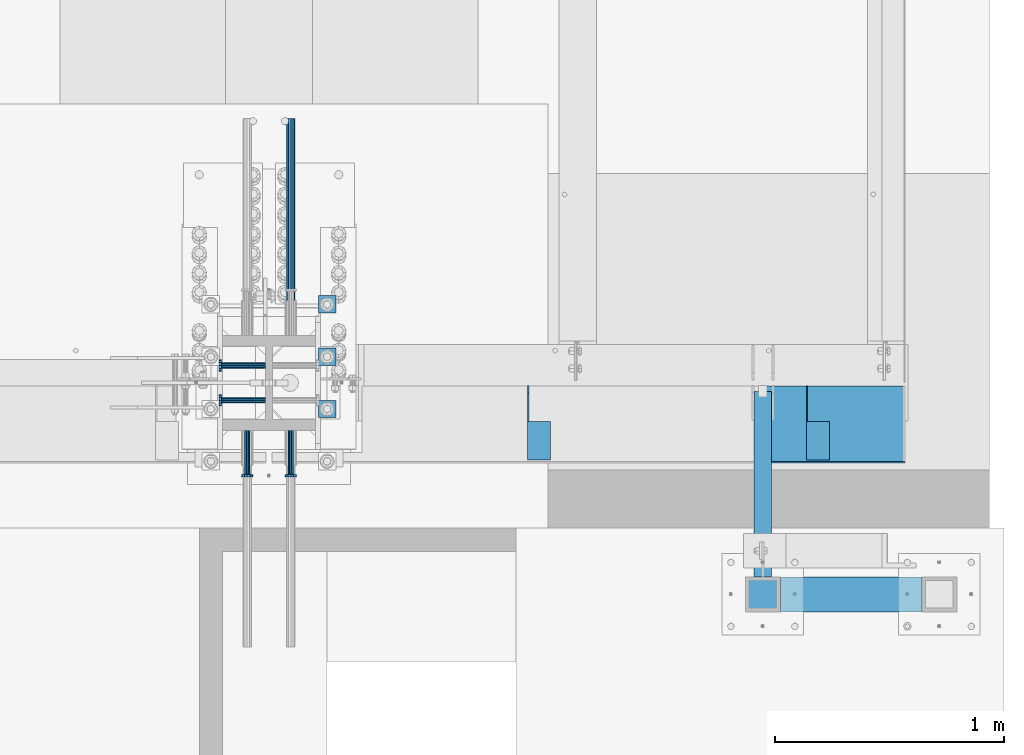
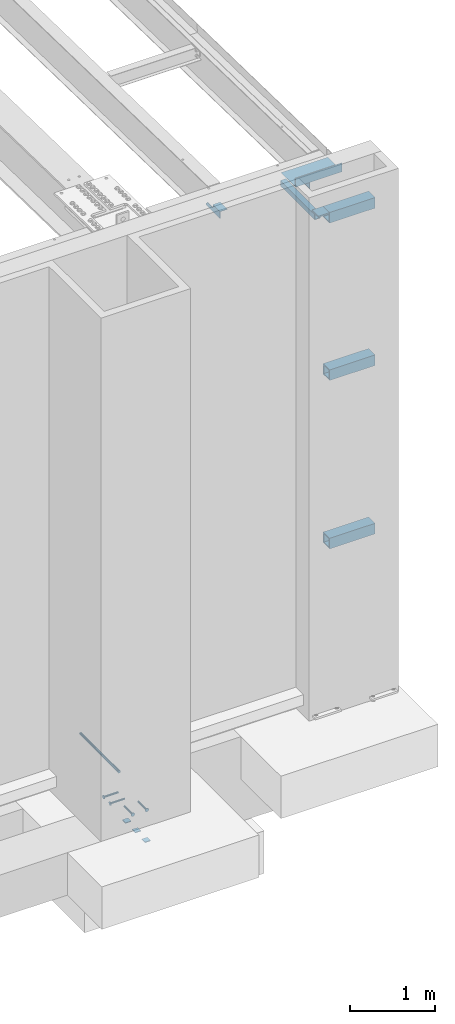
# One storey, part 1300 of 1763: 16 beams, 6 elements without a shape of their own.
"""IFC2X3 building model written with IfcOpenShell, lengths in millimetres."""

from ifc_helpers import new_model, si_unit, frame, origin_with_axes, place, context, subcontext, project, spatial, faceted_brep, material, type_object, element, aggregate, save


model = new_model("IFC2X3")

# Units and contexts
model_context = context("Model", 3, precision=1e-05, world=origin_with_axes())
body_context = subcontext(model_context, "Body", "Model", "MODEL_VIEW")
ifc_project = project(units=[si_unit("LENGTHUNIT", "METRE", prefix="MILLI"), si_unit("AREAUNIT", "SQUARE_METRE"), si_unit("VOLUMEUNIT", "CUBIC_METRE"), si_unit("MASSUNIT", "GRAM", prefix="KILO"), si_unit("TIMEUNIT", "SECOND"), si_unit("PLANEANGLEUNIT", "RADIAN"), si_unit("SOLIDANGLEUNIT", "STERADIAN"), si_unit("THERMODYNAMICTEMPERATUREUNIT", "DEGREE_CELSIUS"), si_unit("LUMINOUSINTENSITYUNIT", "LUMEN")], contexts=[model_context])

# Site, building, storey
site_placement = place(None, origin_with_axes())
site = spatial("IfcSite", under=ifc_project, at=site_placement, CompositionType="ELEMENT")
building_placement = place(site_placement, origin_with_axes())
building = spatial("IfcBuilding", under=site, at=building_placement, Name="Undefined", CompositionType="ELEMENT")
storey_placement = place(building_placement, origin_with_axes())
storey = spatial("IfcBuildingStorey", under=building, at=storey_placement, Name="Undefined", CompositionType="ELEMENT", Elevation=0.0)

# Assembly, beams
assembly_1_placement = place(storey_placement, origin_with_axes())
assembly_1 = element("IfcElementAssembly", 1, at=assembly_1_placement, inside=storey, Name="BEAM", AssemblyPlace="NOTDEFINED", PredefinedType="RIGID_FRAME")
ifc_material_1 = material(Name="STEEL/A36")
beam_type_1 = type_object("IfcBeamType", Name="L4X4X1/4", PredefinedType="NOTDEFINED")
beam_1_placement = place(assembly_1_placement, frame((-21628.4055562795, -13727.906068616, 12153.8999999997), z_axis=(0.0, 0.0, -1.0), x_axis=(0.0, -1.0, 0.0)))
beam_1 = element("IfcBeam", 2, at=beam_1_placement, type_object=beam_type_1, material=ifc_material_1, Name="BRACE", ObjectType="L4X4X1/4", context=body_context, shape_type="Brep", body=[
    faceted_brep([(31.7499984742426, 44.4500000000007, -6.35000000027321), (0.0, 44.4500000000007, 25.3999999997268), (0.0, 50.7999999999993, 25.3999999997268), (31.7499984742426, 50.7999999999993, -6.35000038323415), (-1.96450855582952e-10, 50.8000000000393, 50.7999999999374), (-1.81898940354586e-10, 44.4500000000371, 50.7999999999374), (324.643737794, 44.4500000000007, 50.7999999999993), (324.643737794, 50.7999999999993, 50.7999999999993), (324.643737794, -50.7999999999993, -50.7999999999993), (324.643737794, -50.7999999999993, -44.4500000000007), (156.368568202592, -50.7999999999993, -44.4500000000007), (156.368568386746, -50.7999999999993, -50.7999999999993), (324.643737794, 50.7999999999993, -50.7999999999993), (156.368568386746, 50.7999999999993, -50.7999999999993), (324.643737794, 44.4500000000007, -44.4500000000007), (156.368568202592, 44.4500000000007, -44.4500000000007), (156.368567097667, 44.4500000000007, -6.34999980941575), (156.368567097667, 50.7999999999993, -6.34999980941575)], [[[0, 1, 2, 3]], [[4, 5, 6, 7]], [[8, 9, 10, 11]], [[12, 8, 11, 13]], [[6, 14, 9, 8, 12, 7]], [[9, 14, 15, 10]], [[16, 17, 13, 11, 10, 15]], [[17, 16, 0, 3]], [[4, 7, 12, 13, 17, 3, 2]], [[5, 4, 2, 1]], [[16, 15, 14, 6, 5, 1, 0]]]),
])
beam_2_placement = place(assembly_1_placement, frame((-22847.6055562795, -13727.906068616, 12153.8999999997), z_axis=(0.0, 0.0, -1.0), x_axis=(0.0, -1.0, 0.0)))
beam_2 = element("IfcBeam", 3, at=beam_2_placement, type_object=beam_type_1, material=ifc_material_1, Name="BRACE", ObjectType="L4X4X1/4", context=body_context, shape_type="Brep", body=[
    faceted_brep([(31.7499984742426, 44.4500000000007, -6.35000000027321), (0.0, 44.4500000000007, 25.3999999997268), (0.0, 50.7999999999993, 25.3999999997268), (31.7499984742426, 50.7999999999993, -6.35000038323415), (-1.96450855582952e-10, 50.8000000000393, 50.7999999999374), (-1.81898940354586e-10, 44.4500000000371, 50.7999999999374), (324.643737794, 44.4500000000007, 50.7999999999993), (324.643737794, 50.7999999999993, 50.7999999999993), (324.643737794, -50.7999999999993, -50.7999999999993), (324.643737794, -50.7999999999993, -44.4500000000007), (156.368568202592, -50.7999999999993, -44.4500000000007), (156.368568386746, -50.7999999999993, -50.7999999999993), (324.643737794, 50.7999999999993, -50.7999999999993), (156.368568386746, 50.7999999999993, -50.7999999999993), (324.643737794, 44.4500000000007, -44.4500000000007), (156.368568202592, 44.4500000000007, -44.4500000000007), (156.368567097667, 44.4500000000007, -6.34999980941575), (156.368567097667, 50.7999999999993, -6.34999980941575)], [[[0, 1, 2, 3]], [[4, 5, 6, 7]], [[8, 9, 10, 11]], [[12, 8, 11, 13]], [[6, 14, 9, 8, 12, 7]], [[9, 14, 15, 10]], [[16, 17, 13, 11, 10, 15]], [[17, 16, 0, 3]], [[4, 7, 12, 13, 17, 3, 2]], [[5, 4, 2, 1]], [[16, 15, 14, 6, 5, 1, 0]]]),
])

# Assembly, beam
assembly_2_placement = place(storey_placement, origin_with_axes())
assembly_2 = element("IfcElementAssembly", 4, at=assembly_2_placement, inside=storey, Name="BEAM", AssemblyPlace="NOTDEFINED", PredefinedType="RIGID_FRAME")
ifc_material_2 = material()
beam_type_2 = type_object("IfcBeamType", Name="HSS3X3X1/4", PredefinedType="NOTDEFINED")
beam_3_placement = place(assembly_2_placement, frame((-21868.838056465, -14640.6431168969, 12084.05), z_axis=(0.0, 0.0, 1.0), x_axis=(0.0, 1.0, 0.0)))
beam_3 = element("IfcBeam", 5, at=beam_3_placement, type_object=beam_type_2, material=ifc_material_2, Name="BEAM", ObjectType="HSS3X3X1/4", context=body_context, shape_type="Brep", body=[
    faceted_brep([(76.1998186170622, 31.75, -31.75), (76.1998186170622, -31.75, -31.75), (887.337048279855, -31.75, -31.75), (887.337048279855, 31.75, -31.75), (76.1998186170622, -31.75, 31.75), (887.337048279855, -31.75, 31.75), (76.1998186170622, 31.75, 31.75), (887.337048279855, 31.75, 31.75), (76.1998186170622, 38.0999999999985, -38.1000000000004), (76.1998186170622, 38.0999999999985, 38.1000000000004), (887.337048279855, 38.0999999999985, 38.1000000000004), (887.337048279855, 38.0999999999985, -38.1000000000004), (76.1998186170622, -38.0999999999985, 38.1000000000004), (887.337048279855, -38.0999999999985, 38.1000000000004), (76.1998186170622, -38.0999999999985, -38.1000000000004), (887.337048279855, -38.0999999999985, -38.1000000000004)], [[[0, 1, 2, 3]], [[1, 4, 5, 2]], [[4, 6, 7, 5]], [[6, 0, 3, 7]], [[8, 9, 10, 11]], [[9, 12, 13, 10]], [[12, 14, 15, 13]], [[14, 8, 11, 15]], [[13, 15, 11, 10], [5, 7, 3, 2]], [[14, 12, 9, 8], [6, 4, 1, 0]]]),
])
aggregate(assembly_2, [beam_3])

# Assembly, beams
assembly_3_placement = place(storey_placement, origin_with_axes())
assembly_3 = element("IfcElementAssembly", 6, at=assembly_3_placement, inside=storey, Name="FRAME", AssemblyPlace="NOTDEFINED", PredefinedType="RIGID_FRAME")
beam_type_3 = type_object("IfcBeamType", PredefinedType="NOTDEFINED")
beam_4_placement = place(assembly_3_placement, frame((-21868.838056465, -14716.8432982799, 12195.175), z_axis=(1.0, 0.0, 0.0), x_axis=(0.0, 1.0, 0.0)))
beam_4 = element("IfcBeam", 7, at=beam_4_placement, type_object=beam_type_3, material=ifc_material_1, Name="PLATE", context=body_context, shape_type="Brep", body=[
    faceted_brep([(0.0, 9.52499999999964, -76.1999999999971), (0.0, 9.52499999999964, 76.1999999999971), (152.400000000001, 9.52499999999964, 76.1999999999971), (152.400000000001, 9.52499999999964, -76.1999999999971), (0.0, -9.52499999999964, 76.1999999999971), (152.400000000001, -9.52499999999964, 76.1999999999971), (0.0, -9.52499999999964, -76.1999999999971), (152.400000000001, -9.52499999999964, -76.1999999999971)], [[[0, 1, 2, 3]], [[1, 4, 5, 2]], [[4, 6, 7, 5]], [[6, 0, 3, 7]], [[5, 7, 3, 2]], [[6, 4, 1, 0]]]),
])
beam_type_4 = type_object("IfcBeamType", Name="HSS6X6X5/8", PredefinedType="NOTDEFINED")
beam_5_placement = place(assembly_3_placement, frame((-21868.8380579513, -14640.6432982799, 12128.5), z_axis=(0.0, 0.0, 1.0), x_axis=(1.0, 0.0, 0.0)))
beam_5 = element("IfcBeam", 8, at=beam_5_placement, type_object=beam_type_4, material=ifc_material_2, Name="BEAM", ObjectType="HSS6X6X5/8", context=body_context, shape_type="Brep", body=[
    faceted_brep([(76.2000014863552, 60.3250000000007, -60.3250000000007), (76.2000014863552, -60.3250000000007, -60.3250000000007), (695.325196798858, -60.3250000000007, -60.3250000000007), (695.325196798858, 60.3250000000007, -60.3250000000007), (76.2000027795075, -60.3250000000007, 60.3250000000007), (695.32519809201, -60.3250000000007, 60.3250000000007), (76.2000027795075, 60.3250000000007, 60.3250000000007), (695.32519809201, 60.3250000000007, 60.3250000000007), (76.2000014863552, 76.2000000000007, -76.2000000000007), (76.2000031128846, 76.2000000000007, 76.2000000000007), (695.325198425387, 76.2000000000007, 76.2000000000007), (695.325196798858, 76.2000000000007, -76.2000000000007), (76.2000031128846, -76.2000000000007, 76.2000000000007), (695.325198425387, -76.2000000000007, 76.2000000000007), (76.2000014863552, -76.2000000000007, -76.2000000000007), (695.325196798858, -76.2000000000007, -76.2000000000007)], [[[0, 1, 2, 3]], [[1, 4, 5, 2]], [[4, 6, 7, 5]], [[6, 0, 3, 7]], [[8, 9, 10, 11]], [[9, 12, 13, 10]], [[12, 14, 15, 13]], [[14, 8, 11, 15]], [[13, 15, 11, 10], [5, 7, 3, 2]], [[14, 12, 9, 8], [6, 4, 1, 0]]]),
])
beam_6_placement = place(assembly_3_placement, frame((-21868.8380574559, -14640.6432982799, 9867.9), z_axis=(0.0, 0.0, 1.0), x_axis=(1.0, 0.0, 0.0)))
beam_6 = element("IfcBeam", 9, at=beam_6_placement, type_object=beam_type_4, material=ifc_material_2, Name="BEAM", ObjectType="HSS6X6X5/8", context=body_context, shape_type="Brep", body=[
    faceted_brep([(76.2000014863552, 60.3250000000007, -60.3250000000007), (76.2000014863552, -60.3250000000007, -60.3250000000007), (695.325196798858, -60.3250000000007, -60.3250000000007), (695.325196798858, 60.3250000000007, -60.3250000000007), (76.2000027795075, -60.3250000000007, 60.3250000000007), (695.32519809201, -60.3250000000007, 60.3250000000007), (76.2000027795075, 60.3250000000007, 60.3250000000007), (695.32519809201, 60.3250000000007, 60.3250000000007), (76.2000014863552, 76.2000000000007, -76.2000000000007), (76.2000031128846, 76.2000000000007, 76.2000000000007), (695.325198425387, 76.2000000000007, 76.2000000000007), (695.325196798858, 76.2000000000007, -76.2000000000007), (76.2000031128846, -76.2000000000007, 76.2000000000007), (695.325198425387, -76.2000000000007, 76.2000000000007), (76.2000014863552, -76.2000000000007, -76.2000000000007), (695.325196798858, -76.2000000000007, -76.2000000000007)], [[[0, 1, 2, 3]], [[1, 4, 5, 2]], [[4, 6, 7, 5]], [[6, 0, 3, 7]], [[8, 9, 10, 11]], [[9, 12, 13, 10]], [[12, 14, 15, 13]], [[14, 8, 11, 15]], [[13, 15, 11, 10], [5, 7, 3, 2]], [[14, 12, 9, 8], [6, 4, 1, 0]]]),
])
beam_7_placement = place(assembly_3_placement, frame((-21868.8380569604, -14640.6432982799, 7448.55), z_axis=(0.0, 0.0, 1.0), x_axis=(1.0, 0.0, 0.0)))
beam_7 = element("IfcBeam", 10, at=beam_7_placement, type_object=beam_type_4, material=ifc_material_2, Name="BEAM", ObjectType="HSS6X6X5/8", context=body_context, shape_type="Brep", body=[
    faceted_brep([(76.2000014863552, 60.3250000000007, -60.3250000000007), (76.2000014863552, -60.3250000000007, -60.3250000000007), (695.325196798858, -60.3250000000007, -60.3250000000007), (695.325196798858, 60.3250000000007, -60.3250000000007), (76.2000027795075, -60.3250000000007, 60.3250000000007), (695.32519809201, -60.3250000000007, 60.3250000000007), (76.2000027795075, 60.3250000000007, 60.3250000000007), (695.32519809201, 60.3250000000007, 60.3250000000007), (76.2000014863552, 76.2000000000007, -76.2000000000007), (76.2000031128846, 76.2000000000007, 76.2000000000007), (695.325198425387, 76.2000000000007, 76.2000000000007), (695.325196798858, 76.2000000000007, -76.2000000000007), (76.2000031128846, -76.2000000000007, 76.2000000000007), (695.325198425387, -76.2000000000007, 76.2000000000007), (76.2000014863552, -76.2000000000007, -76.2000000000007), (695.325196798858, -76.2000000000007, -76.2000000000007)], [[[0, 1, 2, 3]], [[1, 4, 5, 2]], [[4, 6, 7, 5]], [[6, 0, 3, 7]], [[8, 9, 10, 11]], [[9, 12, 13, 10]], [[12, 14, 15, 13]], [[14, 8, 11, 15]], [[13, 15, 11, 10], [5, 7, 3, 2]], [[14, 12, 9, 8], [6, 4, 1, 0]]]),
])
aggregate(assembly_3, [beam_5, beam_6, beam_7, beam_4])

assembly_4_placement = place(storey_placement, origin_with_axes())
assembly_4 = element("IfcElementAssembly", 11, at=assembly_4_placement, inside=storey, Name="TEMPLATE", AssemblyPlace="NOTDEFINED", PredefinedType="RIGID_FRAME")
beam_type_5 = type_object("IfcBeamType", PredefinedType="NOTDEFINED")
beam_8_placement = place(assembly_4_placement, frame((-23773.8372736984, -13868.4000000001, 3348.0375), z_axis=(1.0, 0.0, 0.0), x_axis=(0.0, 1.0, 0.0)))
beam_8 = element("IfcBeam", 12, at=beam_8_placement, type_object=beam_type_5, material=ifc_material_1, Name="WASHER PLATE", context=body_context, shape_type="Brep", body=[
    faceted_brep([(0.0, 4.76249999999709, -38.1000000000004), (0.0, 4.76249999999709, 38.1000000000004), (76.2000000000007, 4.76249999999982, 38.0999999999985), (76.2000000000007, 4.76249999999982, -38.0999999999985), (0.0, -4.76249999999709, 38.1000000000004), (76.2000000000007, -4.76249999999982, 38.0999999999985), (0.0, -4.76249999999709, -38.1000000000004), (76.2000000000007, -4.76249999999982, -38.0999999999985)], [[[0, 1, 2, 3]], [[1, 4, 5, 2]], [[4, 6, 7, 5]], [[6, 0, 3, 7]], [[5, 7, 3, 2]], [[6, 4, 1, 0]]]),
])
beam_9_placement = place(assembly_4_placement, frame((-23773.8372736984, -13639.8000000001, 3348.0375), z_axis=(1.0, 0.0, 0.0), x_axis=(0.0, 1.0, 0.0)))
beam_9 = element("IfcBeam", 13, at=beam_9_placement, type_object=beam_type_5, material=ifc_material_1, Name="WASHER PLATE", context=body_context, shape_type="Brep", body=[
    faceted_brep([(0.0, 4.76249999999709, -38.1000000000004), (0.0, 4.76249999999709, 38.1000000000004), (76.2000000000007, 4.76249999999982, 38.0999999999985), (76.2000000000007, 4.76249999999982, -38.0999999999985), (0.0, -4.76249999999709, 38.1000000000004), (76.2000000000007, -4.76249999999982, 38.0999999999985), (0.0, -4.76249999999709, -38.1000000000004), (76.2000000000007, -4.76249999999982, -38.0999999999985)], [[[0, 1, 2, 3]], [[1, 4, 5, 2]], [[4, 6, 7, 5]], [[6, 0, 3, 7]], [[5, 7, 3, 2]], [[6, 4, 1, 0]]]),
])
beam_10_placement = place(assembly_4_placement, frame((-23773.8372736984, -13411.2000000001, 3348.0375), z_axis=(1.0, 0.0, 0.0), x_axis=(0.0, 1.0, 0.0)))
beam_10 = element("IfcBeam", 14, at=beam_10_placement, type_object=beam_type_5, material=ifc_material_1, Name="WASHER PLATE", context=body_context, shape_type="Brep", body=[
    faceted_brep([(0.0, 4.76249999999709, -38.1000000000004), (0.0, 4.76249999999709, 38.1000000000004), (76.2000000000007, 4.76249999999982, 38.0999999999985), (76.2000000000007, 4.76249999999982, -38.0999999999985), (0.0, -4.76249999999709, 38.1000000000004), (76.2000000000007, -4.76249999999982, 38.0999999999985), (0.0, -4.76249999999709, -38.1000000000004), (76.2000000000007, -4.76249999999982, -38.0999999999985)], [[[0, 1, 2, 3]], [[1, 4, 5, 2]], [[4, 6, 7, 5]], [[6, 0, 3, 7]], [[5, 7, 3, 2]], [[6, 4, 1, 0]]]),
])
aggregate(assembly_4, [beam_8, beam_9, beam_10])

# Assembly, beam
assembly_5_placement = place(storey_placement, origin_with_axes())
assembly_5 = element("IfcElementAssembly", 15, at=assembly_5_placement, inside=storey, Name="REBAR", AssemblyPlace="NOTDEFINED", PredefinedType="RIGID_FRAME")
ifc_material_3 = material(Name="STEEL/A706-GR.80")
beam_type_6 = type_object("IfcBeamType", Name="#11 REBAR", PredefinedType="NOTDEFINED")
beam_11_placement = place(assembly_5_placement, frame((-23932.5872736985, -13475.2717516257, 4165.60000000009), z_axis=(0.0, 0.0, 1.0), x_axis=(0.0, 1.0, 0.0)))
beam_11 = element("IfcBeam", 16, at=beam_11_placement, type_object=beam_type_6, material=ifc_material_3, Name="REBAR", ObjectType="#11 REBAR", context=body_context, shape_type="Brep", body=[
    faceted_brep([(0.0, -17.9069999999992, 0.0), (0.0, -15.507916905568, -8.95349999999962), (914.400000001086, -15.507916905568, -8.95349999999962), (914.400000001086, -17.9069999999992, 0.0), (0.0, -8.95349999999962, -15.507916905568), (914.400000001086, -8.95349999999962, -15.507916905568), (0.0, 0.0, -17.9070000000002), (914.400000001086, 0.0, -17.9070000000002), (0.0, 8.95349999999962, -15.507916905568), (914.400000001086, 8.95349999999962, -15.507916905568), (0.0, 15.507916905568, -8.95349999999962), (914.400000001086, 15.507916905568, -8.95349999999962), (0.0, 17.9069999999992, 0.0), (914.400000001086, 17.9069999999992, 0.0), (0.0, 15.507916905568, 8.95349999999962), (914.400000001086, 15.507916905568, 8.95349999999962), (0.0, 8.95349999999962, 15.507916905568), (914.400000001086, 8.95349999999962, 15.507916905568), (0.0, 0.0, 17.9070000000002), (914.400000001086, 0.0, 17.9070000000002), (0.0, -8.95349999999962, 15.507916905568), (914.400000001086, -8.95349999999962, 15.507916905568), (0.0, -15.507916905568, 8.95349999999962), (914.400000001086, -15.507916905568, 8.95349999999962)], [[[0, 1, 2, 3]], [[1, 4, 5, 2]], [[4, 6, 7, 5]], [[6, 8, 9, 7]], [[8, 10, 11, 9]], [[10, 12, 13, 11]], [[12, 14, 15, 13]], [[14, 16, 17, 15]], [[16, 18, 19, 17]], [[18, 20, 21, 19]], [[20, 22, 23, 21]], [[22, 0, 3, 23]], [[5, 7, 9, 11, 13, 15, 17, 19, 21, 23, 3, 2]], [[22, 20, 18, 16, 14, 12, 10, 8, 6, 4, 1, 0]]]),
])
aggregate(assembly_5, [beam_11])

# Assembly, beams
assembly_6_placement = place(storey_placement, origin_with_axes())
assembly_6 = element("IfcElementAssembly", 17, at=assembly_6_placement, inside=storey, Name="COLUMN", AssemblyPlace="NOTDEFINED", PredefinedType="RIGID_FRAME")
ifc_material_4 = material(Name="STEEL/A108")
beam_type_7 = type_object("IfcBeamType", PredefinedType="NOTDEFINED")
beam_12_placement = place(assembly_6_placement, frame((-24042.9185299162, -13639.800000342, 4013.2), z_axis=(0.0, -1.0, 0.0), x_axis=(-1.0, 0.0, 0.0)))
beam_12 = element("IfcBeam", 18, at=beam_12_placement, type_object=beam_type_7, material=ifc_material_4, Name="HEADED STUD ANCHOR", context=body_context, shape_type="Brep", body=[
    faceted_brep([(0.0, -12.6999999999971, -1.81898940354586e-12), (3.63797880709171e-12, -11.0, -6.34999990463257), (191.00799999576, -11.0, -6.34999990454889), (191.007999995752, -12.6999998092651, 8.36735125631094e-11), (7.27595761418343e-12, -6.34999990463257, -11.0), (191.00799999576, -6.34999990463257, -10.9999999999163), (3.63797880709171e-12, 0.0, -12.6999998092651), (191.00799999576, 0.0, -12.6999998091815), (7.27595761418343e-12, 6.34999990463257, -11.0), (191.00799999576, 6.34999990463257, -10.9999999999163), (3.63797880709171e-12, 11.0, -6.34999990463257), (191.00799999576, 11.0, -6.34999990454889), (0.0, 12.6999999999971, -1.81898940354586e-12), (191.007999995752, 12.6999998092651, 8.36735125631094e-11), (0.0, 11.0, 6.34999990463257), (191.007999995752, 11.0, 6.34999990471624), (-3.63797880709171e-12, 6.34999990463257, 11.0), (191.007999995749, 6.34999990463257, 11.0000000000837), (-3.63797880709171e-12, 0.0, 12.6999998092651), (191.007999995749, 0.0, 12.6999998093488), (-3.63797880709171e-12, -6.34999990463257, 11.0), (191.007999995749, -6.34999990463257, 11.0000000000837), (0.0, -11.0, 6.34999990463257), (191.007999995752, -11.0, 6.34999990471624), (193.039999995715, -22.0, -12.6999998091796), (193.039999995708, -25.3999996185303, 8.54925019666553e-11), (193.039999995719, -12.6999998092651, -21.9999999999145), (193.039999995719, 0.0, -25.3999996184448), (193.039999995719, 12.6999998092651, -21.9999999999145), (193.039999995715, 22.0, -12.6999998091796), (193.039999995708, 25.3999996185303, 8.54925019666553e-11), (193.039999995704, 22.0, 12.6999998093506), (193.039999995701, 12.6999998092651, 22.0000000000855), (193.039999995697, 0.0, 25.3999996186158), (193.039999995701, -12.6999998092651, 22.0000000000855), (193.039999995704, -22.0, 12.6999998093506), (203.199999995486, -22.0, -12.6999998091742), (203.199999995482, -25.3999996185303, 9.09494701772928e-11), (203.199999995493, -12.6999998092651, -21.9999999999091), (203.199999995493, 0.0, -25.3999996184393), (203.199999995493, 12.6999998092651, -21.9999999999091), (203.199999995486, 22.0, -12.6999998091742), (203.199999995482, 25.3999996185303, 9.09494701772928e-11), (203.199999995479, 22.0, 12.6999998093561), (203.199999995475, 12.6999998092651, 22.0000000000909), (203.199999995471, 0.0, 25.3999996186212), (203.199999995475, -12.6999998092651, 22.0000000000909), (203.199999995479, -22.0, 12.6999998093561)], [[[0, 1, 2, 3]], [[1, 4, 5, 2]], [[4, 6, 7, 5]], [[6, 8, 9, 7]], [[8, 10, 11, 9]], [[10, 12, 13, 11]], [[12, 14, 15, 13]], [[14, 16, 17, 15]], [[16, 18, 19, 17]], [[18, 20, 21, 19]], [[20, 22, 23, 21]], [[22, 0, 3, 23]], [[22, 20, 18, 16, 14, 12, 10, 8, 6, 4, 1, 0]], [[3, 2, 24, 25]], [[2, 5, 26, 24]], [[5, 7, 27, 26]], [[7, 9, 28, 27]], [[9, 11, 29, 28]], [[11, 13, 30, 29]], [[13, 15, 31, 30]], [[15, 17, 32, 31]], [[17, 19, 33, 32]], [[19, 21, 34, 33]], [[21, 23, 35, 34]], [[23, 3, 25, 35]], [[25, 24, 36, 37]], [[24, 26, 38, 36]], [[26, 27, 39, 38]], [[27, 28, 40, 39]], [[28, 29, 41, 40]], [[29, 30, 42, 41]], [[30, 31, 43, 42]], [[31, 32, 44, 43]], [[32, 33, 45, 44]], [[33, 34, 46, 45]], [[34, 35, 47, 46]], [[35, 25, 37, 47]], [[38, 39, 40, 41, 42, 43, 44, 45, 46, 47, 37, 36]]]),
])
beam_13_placement = place(assembly_6_placement, frame((-24042.9185298019, -13792.2000003411, 4013.2), z_axis=(0.0, -1.0, 0.0), x_axis=(-1.0, 0.0, 0.0)))
beam_13 = element("IfcBeam", 19, at=beam_13_placement, type_object=beam_type_7, material=ifc_material_4, Name="HEADED STUD ANCHOR", context=body_context, shape_type="Brep", body=[
    faceted_brep([(0.0, -12.6999999999971, -1.81898940354586e-12), (3.63797880709171e-12, -11.0, -6.34999990463257), (191.00799999576, -11.0, -6.34999990454889), (191.007999995752, -12.6999998092651, 8.36735125631094e-11), (7.27595761418343e-12, -6.34999990463257, -11.0), (191.00799999576, -6.34999990463257, -10.9999999999163), (3.63797880709171e-12, 0.0, -12.6999998092651), (191.00799999576, 0.0, -12.6999998091815), (7.27595761418343e-12, 6.34999990463257, -11.0), (191.00799999576, 6.34999990463257, -10.9999999999163), (3.63797880709171e-12, 11.0, -6.34999990463257), (191.00799999576, 11.0, -6.34999990454889), (0.0, 12.6999999999971, -1.81898940354586e-12), (191.007999995752, 12.6999998092651, 8.36735125631094e-11), (0.0, 11.0, 6.34999990463257), (191.007999995752, 11.0, 6.34999990471624), (-3.63797880709171e-12, 6.34999990463257, 11.0), (191.007999995749, 6.34999990463257, 11.0000000000837), (-3.63797880709171e-12, 0.0, 12.6999998092651), (191.007999995749, 0.0, 12.6999998093488), (-3.63797880709171e-12, -6.34999990463257, 11.0), (191.007999995749, -6.34999990463257, 11.0000000000837), (0.0, -11.0, 6.34999990463257), (191.007999995752, -11.0, 6.34999990471624), (193.039999995715, -22.0, -12.6999998091796), (193.039999995708, -25.3999996185303, 8.54925019666553e-11), (193.039999995719, -12.6999998092651, -21.9999999999145), (193.039999995719, 0.0, -25.3999996184448), (193.039999995719, 12.6999998092651, -21.9999999999145), (193.039999995715, 22.0, -12.6999998091796), (193.039999995708, 25.3999996185303, 8.54925019666553e-11), (193.039999995704, 22.0, 12.6999998093506), (193.039999995701, 12.6999998092651, 22.0000000000855), (193.039999995697, 0.0, 25.3999996186158), (193.039999995701, -12.6999998092651, 22.0000000000855), (193.039999995704, -22.0, 12.6999998093506), (203.199999995486, -22.0, -12.6999998091742), (203.199999995482, -25.3999996185303, 9.09494701772928e-11), (203.199999995493, -12.6999998092651, -21.9999999999091), (203.199999995493, 0.0, -25.3999996184393), (203.199999995493, 12.6999998092651, -21.9999999999091), (203.199999995486, 22.0, -12.6999998091742), (203.199999995482, 25.3999996185303, 9.09494701772928e-11), (203.199999995479, 22.0, 12.6999998093561), (203.199999995475, 12.6999998092651, 22.0000000000909), (203.199999995471, 0.0, 25.3999996186212), (203.199999995475, -12.6999998092651, 22.0000000000909), (203.199999995479, -22.0, 12.6999998093561)], [[[0, 1, 2, 3]], [[1, 4, 5, 2]], [[4, 6, 7, 5]], [[6, 8, 9, 7]], [[8, 10, 11, 9]], [[10, 12, 13, 11]], [[12, 14, 15, 13]], [[14, 16, 17, 15]], [[16, 18, 19, 17]], [[18, 20, 21, 19]], [[20, 22, 23, 21]], [[22, 0, 3, 23]], [[22, 20, 18, 16, 14, 12, 10, 8, 6, 4, 1, 0]], [[3, 2, 24, 25]], [[2, 5, 26, 24]], [[5, 7, 27, 26]], [[7, 9, 28, 27]], [[9, 11, 29, 28]], [[11, 13, 30, 29]], [[13, 15, 31, 30]], [[15, 17, 32, 31]], [[17, 19, 33, 32]], [[19, 21, 34, 33]], [[21, 23, 35, 34]], [[23, 3, 25, 35]], [[25, 24, 36, 37]], [[24, 26, 38, 36]], [[26, 27, 39, 38]], [[27, 28, 40, 39]], [[28, 29, 41, 40]], [[29, 30, 42, 41]], [[30, 31, 43, 42]], [[31, 32, 44, 43]], [[32, 33, 45, 44]], [[33, 34, 46, 45]], [[34, 35, 47, 46]], [[35, 25, 37, 47]], [[38, 39, 40, 41, 42, 43, 44, 45, 46, 47, 37, 36]]]),
])
beam_14_placement = place(assembly_6_placement, frame((-24123.0872736978, -13923.96256881, 4013.2), z_axis=(1.0, 0.0, 0.0), x_axis=(0.0, -1.0, 0.0)))
beam_14 = element("IfcBeam", 20, at=beam_14_placement, type_object=beam_type_7, material=ifc_material_4, Name="HEADED STUD ANCHOR", context=body_context, shape_type="Brep", body=[
    faceted_brep([(0.0, -12.6999999999971, -1.81898940354586e-12), (3.63797880709171e-12, -11.0, -6.34999990463257), (191.00799999576, -11.0, -6.34999990454889), (191.007999995752, -12.6999998092651, 8.36735125631094e-11), (7.27595761418343e-12, -6.34999990463257, -11.0), (191.00799999576, -6.34999990463257, -10.9999999999163), (3.63797880709171e-12, 0.0, -12.6999998092651), (191.00799999576, 0.0, -12.6999998091815), (7.27595761418343e-12, 6.34999990463257, -11.0), (191.00799999576, 6.34999990463257, -10.9999999999163), (3.63797880709171e-12, 11.0, -6.34999990463257), (191.00799999576, 11.0, -6.34999990454889), (0.0, 12.6999999999971, -1.81898940354586e-12), (191.007999995752, 12.6999998092651, 8.36735125631094e-11), (0.0, 11.0, 6.34999990463257), (191.007999995752, 11.0, 6.34999990471624), (-3.63797880709171e-12, 6.34999990463257, 11.0), (191.007999995749, 6.34999990463257, 11.0000000000837), (-3.63797880709171e-12, 0.0, 12.6999998092651), (191.007999995749, 0.0, 12.6999998093488), (-3.63797880709171e-12, -6.34999990463257, 11.0), (191.007999995749, -6.34999990463257, 11.0000000000837), (0.0, -11.0, 6.34999990463257), (191.007999995752, -11.0, 6.34999990471624), (193.039999995715, -22.0, -12.6999998091796), (193.039999995708, -25.3999996185303, 8.54925019666553e-11), (193.039999995719, -12.6999998092651, -21.9999999999145), (193.039999995719, 0.0, -25.3999996184448), (193.039999995719, 12.6999998092651, -21.9999999999145), (193.039999995715, 22.0, -12.6999998091796), (193.039999995708, 25.3999996185303, 8.54925019666553e-11), (193.039999995704, 22.0, 12.6999998093506), (193.039999995701, 12.6999998092651, 22.0000000000855), (193.039999995697, 0.0, 25.3999996186158), (193.039999995701, -12.6999998092651, 22.0000000000855), (193.039999995704, -22.0, 12.6999998093506), (203.199999995486, -22.0, -12.6999998091742), (203.199999995482, -25.3999996185303, 9.09494701772928e-11), (203.199999995493, -12.6999998092651, -21.9999999999091), (203.199999995493, 0.0, -25.3999996184393), (203.199999995493, 12.6999998092651, -21.9999999999091), (203.199999995486, 22.0, -12.6999998091742), (203.199999995482, 25.3999996185303, 9.09494701772928e-11), (203.199999995479, 22.0, 12.6999998093561), (203.199999995475, 12.6999998092651, 22.0000000000909), (203.199999995471, 0.0, 25.3999996186212), (203.199999995475, -12.6999998092651, 22.0000000000909), (203.199999995479, -22.0, 12.6999998093561)], [[[0, 1, 2, 3]], [[1, 4, 5, 2]], [[4, 6, 7, 5]], [[6, 8, 9, 7]], [[8, 10, 11, 9]], [[10, 12, 13, 11]], [[12, 14, 15, 13]], [[14, 16, 17, 15]], [[16, 18, 19, 17]], [[18, 20, 21, 19]], [[20, 22, 23, 21]], [[22, 0, 3, 23]], [[22, 20, 18, 16, 14, 12, 10, 8, 6, 4, 1, 0]], [[3, 2, 24, 25]], [[2, 5, 26, 24]], [[5, 7, 27, 26]], [[7, 9, 28, 27]], [[9, 11, 29, 28]], [[11, 13, 30, 29]], [[13, 15, 31, 30]], [[15, 17, 32, 31]], [[17, 19, 33, 32]], [[19, 21, 34, 33]], [[21, 23, 35, 34]], [[23, 3, 25, 35]], [[25, 24, 36, 37]], [[24, 26, 38, 36]], [[26, 27, 39, 38]], [[27, 28, 40, 39]], [[28, 29, 41, 40]], [[29, 30, 42, 41]], [[30, 31, 43, 42]], [[31, 32, 44, 43]], [[32, 33, 45, 44]], [[33, 34, 46, 45]], [[34, 35, 47, 46]], [[35, 25, 37, 47]], [[38, 39, 40, 41, 42, 43, 44, 45, 46, 47, 37, 36]]]),
])
beam_15_placement = place(assembly_6_placement, frame((-23932.5872736984, -13923.9626374705, 4013.2), z_axis=(1.0, 0.0, 0.0), x_axis=(0.0, -1.0, 0.0)))
beam_15 = element("IfcBeam", 21, at=beam_15_placement, type_object=beam_type_7, material=ifc_material_4, Name="HEADED STUD ANCHOR", context=body_context, shape_type="Brep", body=[
    faceted_brep([(0.0, -12.6999999999971, -1.81898940354586e-12), (3.63797880709171e-12, -11.0, -6.34999990463257), (191.00799999576, -11.0, -6.34999990454889), (191.007999995752, -12.6999998092651, 8.36735125631094e-11), (7.27595761418343e-12, -6.34999990463257, -11.0), (191.00799999576, -6.34999990463257, -10.9999999999163), (3.63797880709171e-12, 0.0, -12.6999998092651), (191.00799999576, 0.0, -12.6999998091815), (7.27595761418343e-12, 6.34999990463257, -11.0), (191.00799999576, 6.34999990463257, -10.9999999999163), (3.63797880709171e-12, 11.0, -6.34999990463257), (191.00799999576, 11.0, -6.34999990454889), (0.0, 12.6999999999971, -1.81898940354586e-12), (191.007999995752, 12.6999998092651, 8.36735125631094e-11), (0.0, 11.0, 6.34999990463257), (191.007999995752, 11.0, 6.34999990471624), (-3.63797880709171e-12, 6.34999990463257, 11.0), (191.007999995749, 6.34999990463257, 11.0000000000837), (-3.63797880709171e-12, 0.0, 12.6999998092651), (191.007999995749, 0.0, 12.6999998093488), (-3.63797880709171e-12, -6.34999990463257, 11.0), (191.007999995749, -6.34999990463257, 11.0000000000837), (0.0, -11.0, 6.34999990463257), (191.007999995752, -11.0, 6.34999990471624), (193.039999995715, -22.0, -12.6999998091796), (193.039999995708, -25.3999996185303, 8.54925019666553e-11), (193.039999995719, -12.6999998092651, -21.9999999999145), (193.039999995719, 0.0, -25.3999996184448), (193.039999995719, 12.6999998092651, -21.9999999999145), (193.039999995715, 22.0, -12.6999998091796), (193.039999995708, 25.3999996185303, 8.54925019666553e-11), (193.039999995704, 22.0, 12.6999998093506), (193.039999995701, 12.6999998092651, 22.0000000000855), (193.039999995697, 0.0, 25.3999996186158), (193.039999995701, -12.6999998092651, 22.0000000000855), (193.039999995704, -22.0, 12.6999998093506), (203.199999995486, -22.0, -12.6999998091742), (203.199999995482, -25.3999996185303, 9.09494701772928e-11), (203.199999995493, -12.6999998092651, -21.9999999999091), (203.199999995493, 0.0, -25.3999996184393), (203.199999995493, 12.6999998092651, -21.9999999999091), (203.199999995486, 22.0, -12.6999998091742), (203.199999995482, 25.3999996185303, 9.09494701772928e-11), (203.199999995479, 22.0, 12.6999998093561), (203.199999995475, 12.6999998092651, 22.0000000000909), (203.199999995471, 0.0, 25.3999996186212), (203.199999995475, -12.6999998092651, 22.0000000000909), (203.199999995479, -22.0, 12.6999998093561)], [[[0, 1, 2, 3]], [[1, 4, 5, 2]], [[4, 6, 7, 5]], [[6, 8, 9, 7]], [[8, 10, 11, 9]], [[10, 12, 13, 11]], [[12, 14, 15, 13]], [[14, 16, 17, 15]], [[16, 18, 19, 17]], [[18, 20, 21, 19]], [[20, 22, 23, 21]], [[22, 0, 3, 23]], [[22, 20, 18, 16, 14, 12, 10, 8, 6, 4, 1, 0]], [[3, 2, 24, 25]], [[2, 5, 26, 24]], [[5, 7, 27, 26]], [[7, 9, 28, 27]], [[9, 11, 29, 28]], [[11, 13, 30, 29]], [[13, 15, 31, 30]], [[15, 17, 32, 31]], [[17, 19, 33, 32]], [[19, 21, 34, 33]], [[21, 23, 35, 34]], [[23, 3, 25, 35]], [[25, 24, 36, 37]], [[24, 26, 38, 36]], [[26, 27, 39, 38]], [[27, 28, 40, 39]], [[28, 29, 41, 40]], [[29, 30, 42, 41]], [[30, 31, 43, 42]], [[31, 32, 44, 43]], [[32, 33, 45, 44]], [[33, 34, 46, 45]], [[34, 35, 47, 46]], [[35, 25, 37, 47]], [[38, 39, 40, 41, 42, 43, 44, 45, 46, 47, 37, 36]]]),
])
aggregate(assembly_6, [beam_12, beam_13, beam_14, beam_15])

# Beam
beam_type_8 = type_object("IfcBeamType", PredefinedType="NOTDEFINED")
beam_16_placement = place(assembly_1_placement, frame((-21564.0372730615, -13728.6998186171, 12207.875), z_axis=(-1.0, 0.0, 0.0), x_axis=(0.0, -1.0, 0.0)))
beam_16 = element("IfcBeam", 22, at=beam_16_placement, type_object=beam_type_8, material=ifc_material_1, Name="BENT_PLATE", context=body_context, shape_type="Brep", body=[
    faceted_brep([(0.0, -3.17499999999927, -317.5), (0.0, -3.17499999999927, 317.5), (0.0, 3.17499999999927, 317.5), (0.0, 3.17499999999927, -317.5), (330.19998779297, 3.17499999999927, 317.5), (330.19998779297, 3.17499999999927, -317.5), (336.549987792969, -3.17499999999927, -317.5), (336.549987792969, -3.17499999999927, 317.5), (330.19998779297, 123.825000000001, 317.5), (330.19998779297, 123.825000000001, -317.5), (336.549987792969, 123.825000000001, 317.5), (336.549987792969, 123.825000000001, -317.5)], [[[0, 1, 2, 3]], [[3, 2, 4, 5]], [[1, 0, 6, 7]], [[5, 4, 8, 9]], [[4, 2, 1, 7, 10, 8]], [[7, 6, 11, 10]], [[6, 0, 3, 5, 9, 11]], [[10, 11, 9, 8]]]),
])

aggregate(assembly_1, [beam_1, beam_2, beam_16])

save(model, "model.ifc")
